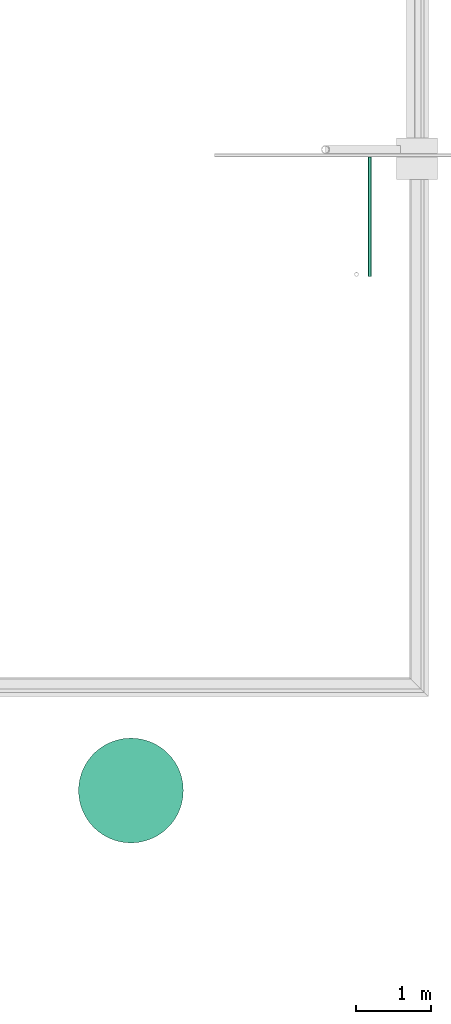
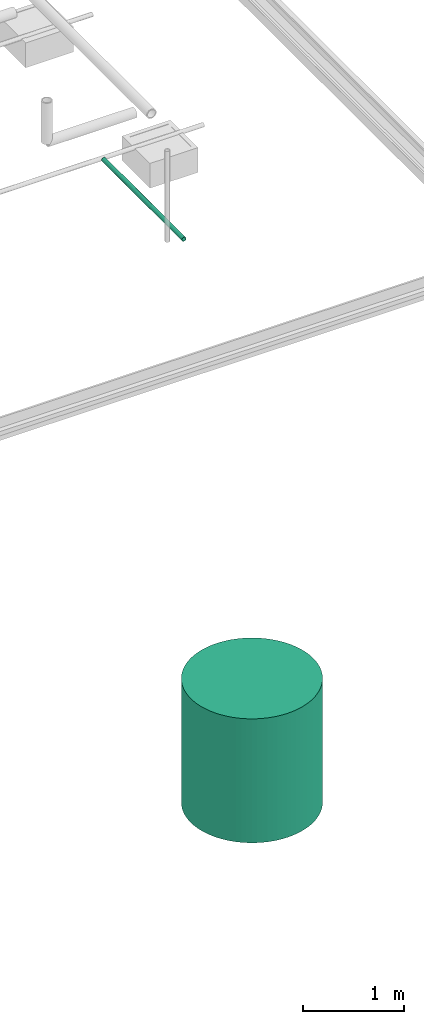
# One storey, part 2 of 15: 1 pipe segment, 1 waste terminal.
"""IFC4X3_ADD2 building model written with IfcOpenShell, lengths in metres."""

from ifc_helpers import new_model, entity, si_unit, converted_unit, frame, origin_with_axes, origin_2d_with_axis, place, context, subcontext, project, spatial, circle, hollow_circle, extrude, material, material_profile, profile_set, profile_usage, type_object, element, save


model = new_model("IFC4X3_ADD2")

# Units and contexts
model_context = context("Model", 3, precision=1e-05, world=origin_with_axes())
plan_context = context("Plan", 2, precision=1e-05, world=origin_2d_with_axis())
body_context = subcontext(model_context, "Body", "Model", "MODEL_VIEW")
ifc_project = project(units=[si_unit("VOLUMEUNIT", "CUBIC_METRE"), si_unit("LENGTHUNIT", "METRE"), converted_unit("PLANEANGLEUNIT", "degree", entity("IfcReal", 0.0174532925199433), si_unit("PLANEANGLEUNIT", "RADIAN"), dimensions=[0, 0, 0, 0, 0, 0, 0]), si_unit("AREAUNIT", "SQUARE_METRE")], contexts=[model_context, plan_context])

# Site, building, storey
site_placement = place(None, origin_with_axes())
site = spatial("IfcSite", under=ifc_project, at=site_placement)
building_placement = place(site_placement, origin_with_axes())
building = spatial("IfcBuilding", under=site, at=building_placement, Name="Building")
storey_placement = place(building_placement, origin_with_axes())
storey = spatial("IfcBuildingStorey", under=building, at=storey_placement, Name="Plumbing")

# Waste terminal
ifc_material = material(Name="Wall")
ifc_material_profile_1 = material_profile(ifc_material, circle(Radius=0.699999988079071))
ifc_profile_set_1 = profile_set([ifc_material_profile_1])
ifc_profile_usage_1 = profile_usage(ifc_profile_set_1, cardinal=5)
waste_terminal_type = type_object("IfcWasteTerminalType", Name="1200mm ID", PredefinedType="USERDEFINED", material=ifc_profile_set_1)
waste_terminal_placement = place(storey_placement, frame((25.5743713378906, 9.13736724853516, 1.19209289550781e-07), z_axis=(-1.50995802528084e-07, -8.74227694680472e-08, -0.999999999999985), x_axis=(-0.999999999999985, 8.74227836789019e-08, 1.50995802528084e-07)))
element("IfcWasteTerminal", 1, at=waste_terminal_placement, inside=storey, type_object=waste_terminal_type, material=ifc_profile_usage_1, Name="WasteTerminal", context=body_context, shape_type="SweptSolid", body=[
    extrude(circle(Radius=0.699999988079071), origin_with_axes(), (0.0, 0.0, 1.0), 1.5),
])

# Pipe segment
ifc_material_profile_2 = material_profile(ifc_material, hollow_circle(Radius=0.0253999996930361, WallThickness=0.0020000000949949))
ifc_profile_set_2 = profile_set([ifc_material_profile_2])
ifc_profile_usage_2 = profile_usage(ifc_profile_set_2)
ifc_material_profile_3 = material_profile(ifc_material, hollow_circle(Radius=0.0253999996930361, WallThickness=0.0020000000949949))
ifc_profile_set_3 = profile_set([ifc_material_profile_3])
pipe_segment_type = type_object("IfcPipeSegmentType", Name="2inch-bath outlet", PredefinedType="FLEXIBLESEGMENT", material=ifc_profile_set_3)
pipe_segment_placement = place(storey_placement, frame((28.7677593231201, 16.0149307250977, 0.0252151470631361), z_axis=(-1.50995774106375e-07, 0.999999999999986, 7.54979012640422e-08), x_axis=(-0.999999999999913, -1.50995802528073e-07, 3.89414424262179e-07)))
element("IfcPipeSegment", 2, at=pipe_segment_placement, inside=storey, type_object=pipe_segment_type, material=ifc_profile_usage_2, Name="PipeSegment", context=body_context, shape_type="SweptSolid", body=[
    extrude(hollow_circle(Radius=0.0253999996930361, WallThickness=0.0020000000949949), origin_with_axes(), (0.0, 0.0, 1.0), 1.59302713793229),
])

save(model, "model.ifc")
